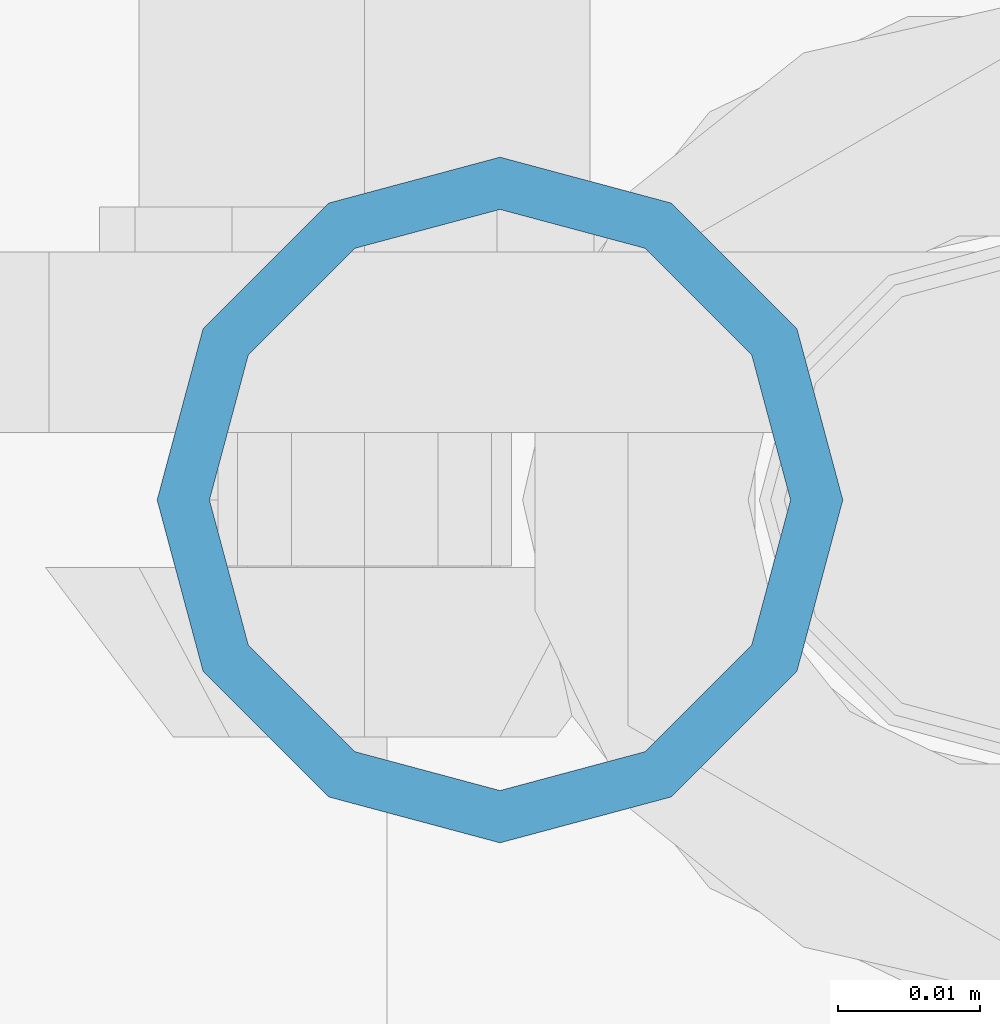
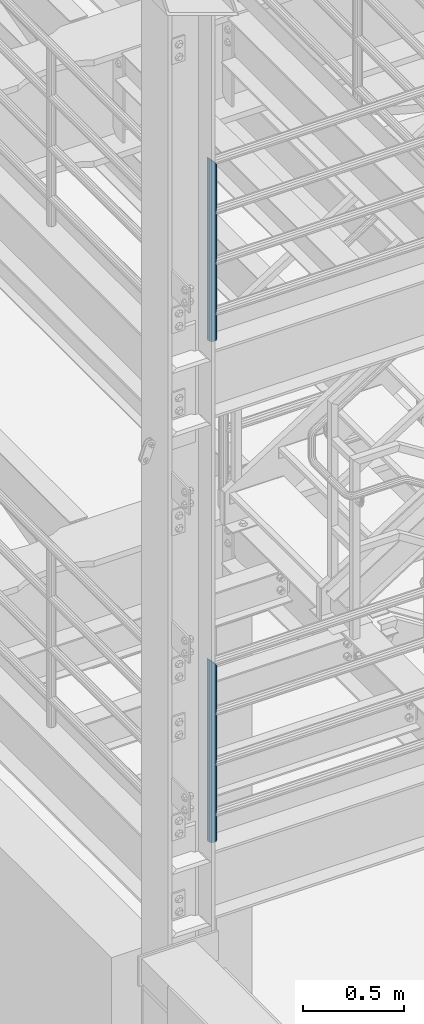
# One storey, part 556 of 1876: 2 columns, 2 elements without a shape of their own.
"""IFC2X3 building model written with IfcOpenShell, lengths in millimetres."""

from ifc_helpers import new_model, si_unit, frame, origin_with_axes, place, context, subcontext, project, spatial, faceted_brep, material, type_object, element, aggregate, save


model = new_model("IFC2X3")

# Units and contexts
model_context = context("Model", 3, precision=1e-05, world=origin_with_axes())
body_context = subcontext(model_context, "Body", "Model", "MODEL_VIEW")
ifc_project = project(units=[si_unit("LENGTHUNIT", "METRE", prefix="MILLI"), si_unit("AREAUNIT", "SQUARE_METRE"), si_unit("VOLUMEUNIT", "CUBIC_METRE"), si_unit("MASSUNIT", "GRAM", prefix="KILO"), si_unit("TIMEUNIT", "SECOND"), si_unit("PLANEANGLEUNIT", "RADIAN"), si_unit("SOLIDANGLEUNIT", "STERADIAN"), si_unit("THERMODYNAMICTEMPERATUREUNIT", "DEGREE_CELSIUS"), si_unit("LUMINOUSINTENSITYUNIT", "LUMEN")], contexts=[model_context])

# Site, building, storey
site_placement = place(None, origin_with_axes())
site = spatial("IfcSite", under=ifc_project, at=site_placement, CompositionType="ELEMENT")
building_placement = place(site_placement, origin_with_axes())
building = spatial("IfcBuilding", under=site, at=building_placement, Name="Undefined", CompositionType="ELEMENT")
storey_placement = place(building_placement, origin_with_axes())
storey = spatial("IfcBuildingStorey", under=building, at=storey_placement, Name="Undefined", CompositionType="ELEMENT", Elevation=0.0)

# Assembly, column
assembly_1_placement = place(storey_placement, origin_with_axes())
assembly_1 = element("IfcElementAssembly", 1, at=assembly_1_placement, inside=storey, Name="RAIL", AssemblyPlace="NOTDEFINED", PredefinedType="RIGID_FRAME")
ifc_material = material()
column_type = type_object("IfcColumnType", Name="PIPE1-1/2SCH40", PredefinedType="NOTDEFINED")
column_1_placement = place(assembly_1_placement, frame((192.0875, -7112.0, 5130.8), z_axis=(0.0, 1.0, 0.0), x_axis=(0.0, 0.0, 1.0)))
column_1 = element("IfcColumn", 2, at=column_1_placement, type_object=column_type, material=ifc_material, Name="POST", ObjectType="PIPE1-1/2SCH40", context=body_context, shape_type="Brep", body=[
    faceted_brep([(0.0, -20.4469999999999, 0.0), (0.0, -17.7076214311803, 10.2235000000001), (1094.03262143118, -17.7076214311804, 10.2235000000001), (1096.772, -20.447, 0.0), (0.0, -10.2235000000001, 17.7076214311801), (1086.5485, -10.2235, 17.7076214311801), (-1.45519152283669e-11, 0.0, 20.4470000000001), (1076.325, 0.0, 20.4470000000001), (0.0, 10.2235000000001, 17.7076214311801), (1066.1015, 10.2235, 17.7076214311801), (0.0, 17.7076214311803, 10.2235000000001), (1058.61737856882, 17.7076214311804, 10.2235000000001), (0.0, 20.4469999999999, 0.0), (1055.878, 20.447, 0.0), (0.0, 17.7076214311803, -10.2235000000001), (1058.61737856882, 17.7076214311804, -10.2235000000001), (0.0, 10.2235000000001, -17.7076214311801), (1066.1015, 10.2235, -17.7076214311801), (-1.45519152283669e-11, 0.0, -20.4470000000001), (1076.325, 0.0, -20.4470000000001), (0.0, -10.2235000000001, -17.7076214311801), (1086.5485, -10.2235, -17.7076214311801), (0.0, -17.7076214311803, -10.2235000000001), (1094.03262143118, -17.7076214311804, -10.2235000000001), (0.0, -24.1299999999992, 0.0), (0.0, -20.8971929933184, -12.0649999999996), (1097.22219299332, -20.8971929933185, -12.0649999999996), (1100.455, -24.13, 0.0), (0.0, -12.0650000000001, -20.8971929933186), (1088.39, -12.065, -20.8971929933186), (-1.45519152283669e-11, 0.0, -24.130000000001), (1076.325, 0.0, -24.1300000000001), (0.0, 12.0650000000001, -20.8971929933186), (1064.26, 12.065, -20.8971929933186), (0.0, 20.8971929933184, -12.0649999999996), (1055.42780700668, 20.8971929933185, -12.0649999999996), (0.0, 24.1299999999992, 0.0), (1052.195, 24.13, 0.0), (0.0, 20.8971929933184, 12.0649999999996), (1055.42780700668, 20.8971929933185, 12.0649999999996), (0.0, 12.0650000000001, 20.8971929933186), (1064.26, 12.065, 20.8971929933186), (-1.45519152283669e-11, 0.0, 24.130000000001), (1076.325, 0.0, 24.1300000000001), (0.0, -12.0650000000001, 20.8971929933186), (1088.39, -12.065, 20.8971929933186), (0.0, -20.8971929933184, 12.0649999999996), (1097.22219299332, -20.8971929933185, 12.0649999999996)], [[[0, 1, 2, 3]], [[1, 4, 5, 2]], [[4, 6, 7, 5]], [[6, 8, 9, 7]], [[8, 10, 11, 9]], [[10, 12, 13, 11]], [[12, 14, 15, 13]], [[14, 16, 17, 15]], [[16, 18, 19, 17]], [[18, 20, 21, 19]], [[20, 22, 23, 21]], [[22, 0, 3, 23]], [[24, 25, 26, 27]], [[25, 28, 29, 26]], [[28, 30, 31, 29]], [[30, 32, 33, 31]], [[32, 34, 35, 33]], [[34, 36, 37, 35]], [[36, 38, 39, 37]], [[38, 40, 41, 39]], [[40, 42, 43, 41]], [[42, 44, 45, 43]], [[44, 46, 47, 45]], [[46, 24, 27, 47]], [[29, 31, 33, 35, 37, 39, 41, 43, 45, 47, 27, 26], [5, 7, 9, 11, 13, 15, 17, 19, 21, 23, 3, 2]], [[46, 44, 42, 40, 38, 36, 34, 32, 30, 28, 25, 24], [22, 20, 18, 16, 14, 12, 10, 8, 6, 4, 1, 0]]]),
])
aggregate(assembly_1, [column_1])

assembly_2_placement = place(storey_placement, origin_with_axes())
assembly_2 = element("IfcElementAssembly", 3, at=assembly_2_placement, inside=storey, Name="RAIL", AssemblyPlace="NOTDEFINED", PredefinedType="RIGID_FRAME")
column_2_placement = place(assembly_2_placement, frame((192.0875, -7112.0, 8153.4), z_axis=(0.0, 1.0, 0.0), x_axis=(0.0, 0.0, 1.0)))
column_2 = element("IfcColumn", 4, at=column_2_placement, type_object=column_type, material=ifc_material, Name="POST", ObjectType="PIPE1-1/2SCH40", context=body_context, shape_type="Brep", body=[
    faceted_brep([(0.0, -20.4469999999999, 0.0), (0.0, -17.7076214311803, 10.2235000000001), (1094.03262143118, -17.7076214311804, 10.2235000000001), (1096.772, -20.447, 0.0), (0.0, -10.2235000000001, 17.7076214311801), (1086.5485, -10.2235, 17.7076214311801), (-1.45519152283669e-11, 0.0, 20.4470000000001), (1076.325, 0.0, 20.4470000000001), (0.0, 10.2235000000001, 17.7076214311801), (1066.1015, 10.2235, 17.7076214311801), (0.0, 17.7076214311803, 10.2235000000001), (1058.61737856882, 17.7076214311804, 10.2235000000001), (0.0, 20.4469999999999, 0.0), (1055.878, 20.447, 0.0), (0.0, 17.7076214311803, -10.2235000000001), (1058.61737856882, 17.7076214311804, -10.2235000000001), (0.0, 10.2235000000001, -17.7076214311801), (1066.1015, 10.2235, -17.7076214311801), (-1.45519152283669e-11, 0.0, -20.4470000000001), (1076.325, 0.0, -20.4470000000001), (0.0, -10.2235000000001, -17.7076214311801), (1086.5485, -10.2235, -17.7076214311801), (0.0, -17.7076214311803, -10.2235000000001), (1094.03262143118, -17.7076214311804, -10.2235000000001), (0.0, -24.1299999999992, 0.0), (0.0, -20.8971929933184, -12.0649999999996), (1097.22219299332, -20.8971929933185, -12.0649999999996), (1100.455, -24.13, 0.0), (0.0, -12.0650000000001, -20.8971929933186), (1088.39, -12.065, -20.8971929933186), (-1.45519152283669e-11, 0.0, -24.130000000001), (1076.325, 0.0, -24.1300000000001), (0.0, 12.0650000000001, -20.8971929933186), (1064.26, 12.065, -20.8971929933186), (0.0, 20.8971929933184, -12.0649999999996), (1055.42780700668, 20.8971929933185, -12.0649999999996), (0.0, 24.1299999999992, 0.0), (1052.195, 24.13, 0.0), (0.0, 20.8971929933184, 12.0649999999996), (1055.42780700668, 20.8971929933185, 12.0649999999996), (0.0, 12.0650000000001, 20.8971929933186), (1064.26, 12.065, 20.8971929933186), (-1.45519152283669e-11, 0.0, 24.130000000001), (1076.325, 0.0, 24.1300000000001), (0.0, -12.0650000000001, 20.8971929933186), (1088.39, -12.065, 20.8971929933186), (0.0, -20.8971929933184, 12.0649999999996), (1097.22219299332, -20.8971929933185, 12.0649999999996)], [[[0, 1, 2, 3]], [[1, 4, 5, 2]], [[4, 6, 7, 5]], [[6, 8, 9, 7]], [[8, 10, 11, 9]], [[10, 12, 13, 11]], [[12, 14, 15, 13]], [[14, 16, 17, 15]], [[16, 18, 19, 17]], [[18, 20, 21, 19]], [[20, 22, 23, 21]], [[22, 0, 3, 23]], [[24, 25, 26, 27]], [[25, 28, 29, 26]], [[28, 30, 31, 29]], [[30, 32, 33, 31]], [[32, 34, 35, 33]], [[34, 36, 37, 35]], [[36, 38, 39, 37]], [[38, 40, 41, 39]], [[40, 42, 43, 41]], [[42, 44, 45, 43]], [[44, 46, 47, 45]], [[46, 24, 27, 47]], [[29, 31, 33, 35, 37, 39, 41, 43, 45, 47, 27, 26], [5, 7, 9, 11, 13, 15, 17, 19, 21, 23, 3, 2]], [[46, 44, 42, 40, 38, 36, 34, 32, 30, 28, 25, 24], [22, 20, 18, 16, 14, 12, 10, 8, 6, 4, 1, 0]]]),
])
aggregate(assembly_2, [column_2])

save(model, "model.ifc")
